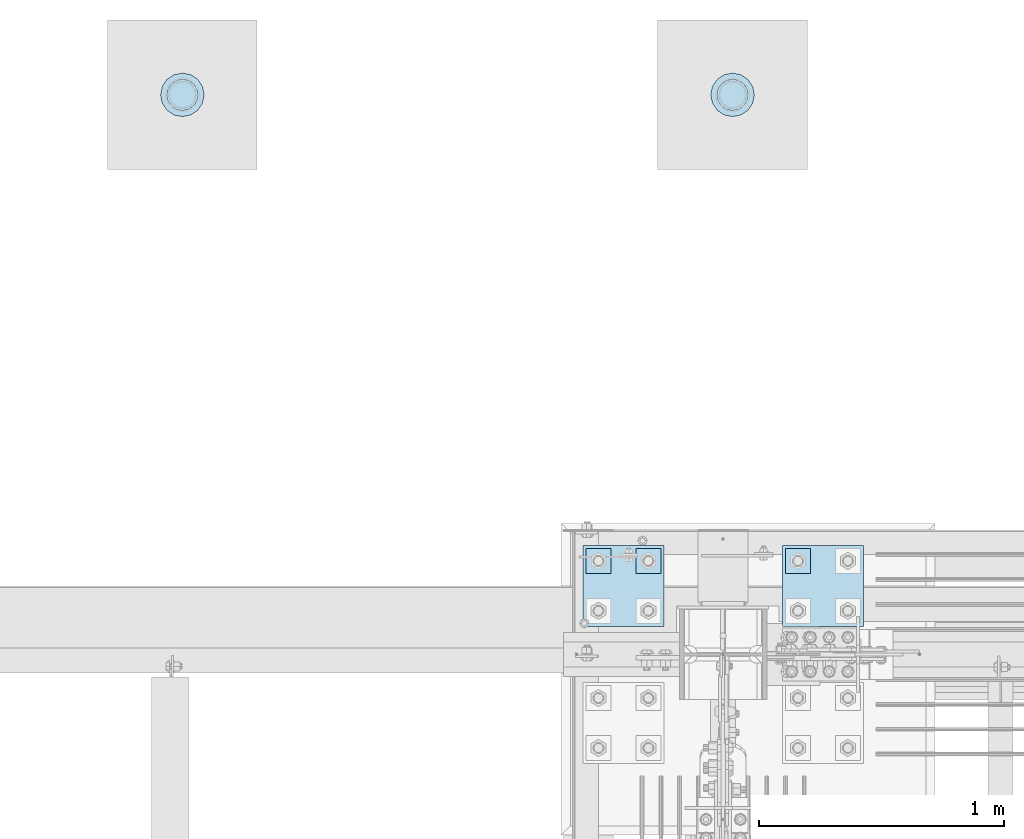
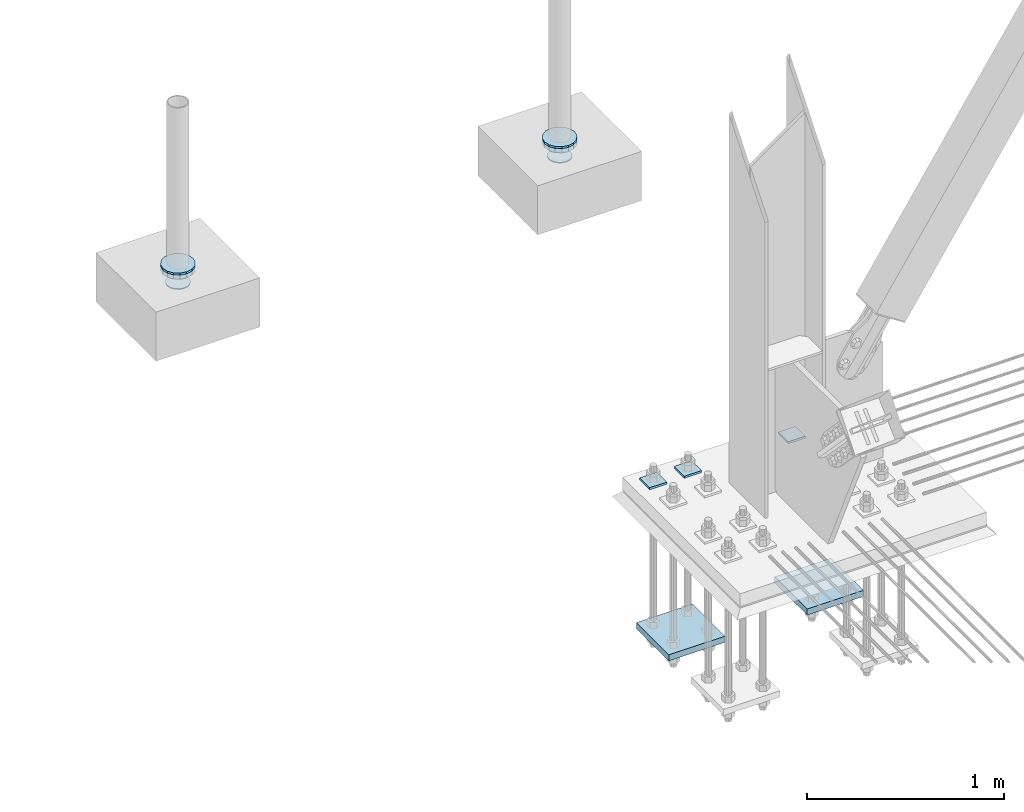
# One storey, part 3541 of 3843: 11 plates, 5 elements without a shape of their own.
"""IFC2X3 building model written with IfcOpenShell, lengths in millimetres."""

from ifc_helpers import new_model, si_unit, frame, origin_with_axes, place, context, subcontext, project, spatial, faceted_brep, material, type_object, element, aggregate, save


model = new_model("IFC2X3")

# Units and contexts
model_context = context("Model", 3, precision=1e-05, world=origin_with_axes())
body_context = subcontext(model_context, "Body", "Model", "MODEL_VIEW")
ifc_project = project(units=[si_unit("LENGTHUNIT", "METRE", prefix="MILLI"), si_unit("AREAUNIT", "SQUARE_METRE"), si_unit("VOLUMEUNIT", "CUBIC_METRE"), si_unit("MASSUNIT", "GRAM", prefix="KILO"), si_unit("TIMEUNIT", "SECOND"), si_unit("PLANEANGLEUNIT", "RADIAN"), si_unit("SOLIDANGLEUNIT", "STERADIAN"), si_unit("THERMODYNAMICTEMPERATUREUNIT", "DEGREE_CELSIUS"), si_unit("LUMINOUSINTENSITYUNIT", "LUMEN")], contexts=[model_context])

# Site, building, storey
site_placement = place(None, origin_with_axes())
site = spatial("IfcSite", under=ifc_project, at=site_placement, CompositionType="ELEMENT")
building_placement = place(site_placement, origin_with_axes())
building = spatial("IfcBuilding", under=site, at=building_placement, Name="Undefined", CompositionType="ELEMENT")
storey_placement = place(building_placement, origin_with_axes())
storey = spatial("IfcBuildingStorey", under=building, at=storey_placement, Name="Undefined", CompositionType="ELEMENT", Elevation=0.0)

# Assembly, plate
assembly_1_placement = place(storey_placement, origin_with_axes())
assembly_1 = element("IfcElementAssembly", 1, at=assembly_1_placement, inside=storey, Name="PIPE_BOLLARD", AssemblyPlace="NOTDEFINED", PredefinedType="RIGID_FRAME")
ifc_material = material(Name="STEEL/A572-50")
plate_type_1 = type_object("IfcPlateType", PredefinedType="NOTDEFINED")
plate_1_placement = place(assembly_1_placement, frame((76962.1673368275, 106927.878119135, 30486.35), z_axis=(1.0, 0.0, 0.0), x_axis=(0.0, -1.0, 0.0)))
plate_1 = element("IfcPlate", 2, at=plate_1_placement, type_object=plate_type_1, material=ifc_material, Name="PLATE", context=body_context, shape_type="Brep", body=[
    faceted_brep([(0.0, -6.34999999999854, 88.9000015258789), (6.76710967589679, -6.34999999999854, 122.920556195299), (6.76710967589679, 6.34999999999854, 122.920556195299), (0.0, 6.34999999999854, 88.9000015258789), (26.0382075994357, -6.34999999999854, 151.761792400561), (26.0382075994357, 6.34999999999854, 151.761792400561), (54.8794438046934, -6.34999999999854, 171.032890324102), (54.8794438046934, 6.34999999999854, 171.032890324102), (88.8999984741095, -6.34999999999854, 177.800000000003), (88.8999984741095, 6.34999999999854, 177.800000000003), (122.920556195295, -6.34999999999854, 171.032890324102), (122.920556195295, 6.34999999999854, 171.032890324102), (151.761792400553, -6.34999999999854, 151.761792400561), (151.761792400553, 6.34999999999854, 151.761792400561), (171.032890324092, -6.34999999999854, 122.920556195299), (171.032890324092, 6.34999999999854, 122.920556195299), (177.799999999988, -6.34999999999854, 88.9000015258789), (177.799999999988, 6.34999999999854, 88.9000015258789), (171.032890324091, -6.34999999999854, 54.8794438046898), (171.032890324091, 6.34999999999854, 54.8794438046898), (151.761792400553, -6.34999999999854, 26.0382075994421), (151.761792400553, 6.34999999999854, 26.0382075994421), (122.920556195295, -6.34999999999854, 6.76710967590043), (122.920556195295, 6.34999999999854, 6.76710967590043), (88.9000015258789, -6.34999999999854, 0.0), (88.9000015258789, 6.34999999999854, 0.0), (54.8794438046934, -6.34999999999854, 6.76710967590043), (54.8794438046934, 6.34999999999854, 6.76710967590043), (26.0382075994357, -6.34999999999854, 26.0382075994421), (26.0382075994357, 6.34999999999854, 26.0382075994421), (6.76710967589679, -6.34999999999854, 54.8794438046898), (6.76710967589679, 6.34999999999854, 54.8794438046898)], [[[0, 1, 2, 3]], [[1, 4, 5, 2]], [[4, 6, 7, 5]], [[6, 8, 9, 7]], [[8, 10, 11, 9]], [[10, 12, 13, 11]], [[12, 14, 15, 13]], [[14, 16, 17, 15]], [[16, 18, 19, 17]], [[18, 20, 21, 19]], [[20, 22, 23, 21]], [[22, 24, 25, 23]], [[24, 26, 27, 25]], [[26, 28, 29, 27]], [[28, 30, 31, 29]], [[30, 0, 3, 31]], [[5, 7, 9, 11, 13, 15, 17, 19, 21, 23, 25, 27, 29, 31, 3, 2]], [[30, 28, 26, 24, 22, 20, 18, 16, 14, 12, 10, 8, 6, 4, 1, 0]]]),
])
aggregate(assembly_1, [plate_1])

assembly_2_placement = place(storey_placement, origin_with_axes())
assembly_2 = element("IfcElementAssembly", 3, at=assembly_2_placement, inside=storey, Name="PIPE_BOLLARD", AssemblyPlace="NOTDEFINED", PredefinedType="RIGID_FRAME")
plate_2_placement = place(assembly_2_placement, frame((74720.7237027943, 106927.881933832, 30486.35), z_axis=(1.0, 0.0, 0.0), x_axis=(0.0, -1.0, 0.0)))
plate_2 = element("IfcPlate", 4, at=plate_2_placement, type_object=plate_type_1, material=ifc_material, Name="PLATE", context=body_context, shape_type="Brep", body=[
    faceted_brep([(0.0, -6.34999999999854, 88.9000015258789), (6.76710967589679, -6.34999999999854, 122.920556195299), (6.76710967589679, 6.34999999999854, 122.920556195299), (0.0, 6.34999999999854, 88.9000015258789), (26.0382075994357, -6.34999999999854, 151.761792400561), (26.0382075994357, 6.34999999999854, 151.761792400561), (54.8794438046934, -6.34999999999854, 171.032890324102), (54.8794438046934, 6.34999999999854, 171.032890324102), (88.8999984741095, -6.34999999999854, 177.800000000003), (88.8999984741095, 6.34999999999854, 177.800000000003), (122.920556195295, -6.34999999999854, 171.032890324102), (122.920556195295, 6.34999999999854, 171.032890324102), (151.761792400553, -6.34999999999854, 151.761792400561), (151.761792400553, 6.34999999999854, 151.761792400561), (171.032890324092, -6.34999999999854, 122.920556195299), (171.032890324092, 6.34999999999854, 122.920556195299), (177.799999999988, -6.34999999999854, 88.9000015258789), (177.799999999988, 6.34999999999854, 88.9000015258789), (171.032890324091, -6.34999999999854, 54.8794438046898), (171.032890324091, 6.34999999999854, 54.8794438046898), (151.761792400553, -6.34999999999854, 26.0382075994421), (151.761792400553, 6.34999999999854, 26.0382075994421), (122.920556195295, -6.34999999999854, 6.76710967590043), (122.920556195295, 6.34999999999854, 6.76710967590043), (88.9000015258789, -6.34999999999854, 0.0), (88.9000015258789, 6.34999999999854, 0.0), (54.8794438046934, -6.34999999999854, 6.76710967590043), (54.8794438046934, 6.34999999999854, 6.76710967590043), (26.0382075994357, -6.34999999999854, 26.0382075994421), (26.0382075994357, 6.34999999999854, 26.0382075994421), (6.76710967589679, -6.34999999999854, 54.8794438046898), (6.76710967589679, 6.34999999999854, 54.8794438046898)], [[[0, 1, 2, 3]], [[1, 4, 5, 2]], [[4, 6, 7, 5]], [[6, 8, 9, 7]], [[8, 10, 11, 9]], [[10, 12, 13, 11]], [[12, 14, 15, 13]], [[14, 16, 17, 15]], [[16, 18, 19, 17]], [[18, 20, 21, 19]], [[20, 22, 23, 21]], [[22, 24, 25, 23]], [[24, 26, 27, 25]], [[26, 28, 29, 27]], [[28, 30, 31, 29]], [[30, 0, 3, 31]], [[5, 7, 9, 11, 13, 15, 17, 19, 21, 23, 25, 27, 29, 31, 3, 2]], [[30, 28, 26, 24, 22, 20, 18, 16, 14, 12, 10, 8, 6, 4, 1, 0]]]),
])
aggregate(assembly_2, [plate_2])

assembly_3_placement = place(storey_placement, origin_with_axes())
assembly_3 = element("IfcElementAssembly", 5, at=assembly_3_placement, inside=storey, Name="PLATE", AssemblyPlace="NOTDEFINED", PredefinedType="RIGID_FRAME")
plate_type_2 = type_object("IfcPlateType", PredefinedType="NOTDEFINED")
plate_3_placement = place(assembly_3_placement, frame((76962.1673368275, 106927.878119135, 30467.3), z_axis=(1.0, 0.0, 0.0), x_axis=(0.0, -1.0, 0.0)))
plate_3 = element("IfcPlate", 6, at=plate_3_placement, type_object=plate_type_2, material=ifc_material, Name="PLATE", context=body_context, shape_type="Brep", body=[
    faceted_brep([(0.0, -12.7000000000007, 88.9000015258789), (6.76710967589679, -12.7000000000007, 122.920556195299), (6.76710967589679, 12.7000000000007, 122.920556195299), (0.0, 12.7000000000007, 88.9000015258789), (26.0382075994357, -12.7000000000007, 151.761792400561), (26.0382075994357, 12.7000000000007, 151.761792400561), (54.8794438046934, -12.7000000000007, 171.032890324102), (54.8794438046934, 12.7000000000007, 171.032890324102), (88.8999984741095, -12.7000000000007, 177.800000000003), (88.8999984741095, 12.7000000000007, 177.800000000003), (122.920556195295, -12.7000000000007, 171.032890324102), (122.920556195295, 12.7000000000007, 171.032890324102), (151.761792400553, -12.7000000000007, 151.761792400561), (151.761792400553, 12.7000000000007, 151.761792400561), (171.032890324092, -12.7000000000007, 122.920556195299), (171.032890324092, 12.7000000000007, 122.920556195299), (177.799999999988, -12.7000000000007, 88.9000015258789), (177.799999999988, 12.7000000000007, 88.9000015258789), (171.032890324091, -12.7000000000007, 54.8794438046898), (171.032890324091, 12.7000000000007, 54.8794438046898), (151.761792400553, -12.7000000000007, 26.0382075994421), (151.761792400553, 12.7000000000007, 26.0382075994421), (122.920556195295, -12.7000000000007, 6.76710967590043), (122.920556195295, 12.7000000000007, 6.76710967590043), (88.9000015258789, -12.7000000000007, 0.0), (88.9000015258789, 12.7000000000007, 0.0), (54.8794438046934, -12.7000000000007, 6.76710967590043), (54.8794438046934, 12.7000000000007, 6.76710967590043), (26.0382075994357, -12.7000000000007, 26.0382075994421), (26.0382075994357, 12.7000000000007, 26.0382075994421), (6.76710967589679, -12.7000000000007, 54.8794438046898), (6.76710967589679, 12.7000000000007, 54.8794438046898)], [[[0, 1, 2, 3]], [[1, 4, 5, 2]], [[4, 6, 7, 5]], [[6, 8, 9, 7]], [[8, 10, 11, 9]], [[10, 12, 13, 11]], [[12, 14, 15, 13]], [[14, 16, 17, 15]], [[16, 18, 19, 17]], [[18, 20, 21, 19]], [[20, 22, 23, 21]], [[22, 24, 25, 23]], [[24, 26, 27, 25]], [[26, 28, 29, 27]], [[28, 30, 31, 29]], [[30, 0, 3, 31]], [[5, 7, 9, 11, 13, 15, 17, 19, 21, 23, 25, 27, 29, 31, 3, 2]], [[30, 28, 26, 24, 22, 20, 18, 16, 14, 12, 10, 8, 6, 4, 1, 0]]]),
])

assembly_4_placement = place(storey_placement, origin_with_axes())
assembly_4 = element("IfcElementAssembly", 7, at=assembly_4_placement, inside=storey, Name="PLATE", AssemblyPlace="NOTDEFINED", PredefinedType="RIGID_FRAME")
plate_4_placement = place(assembly_4_placement, frame((74720.7237027943, 106927.881933832, 30467.3), z_axis=(1.0, 0.0, 0.0), x_axis=(0.0, -1.0, 0.0)))
plate_4 = element("IfcPlate", 8, at=plate_4_placement, type_object=plate_type_2, material=ifc_material, Name="PLATE", context=body_context, shape_type="Brep", body=[
    faceted_brep([(0.0, -12.7000000000007, 88.9000015258789), (6.76710967589679, -12.7000000000007, 122.920556195299), (6.76710967589679, 12.7000000000007, 122.920556195299), (0.0, 12.7000000000007, 88.9000015258789), (26.0382075994357, -12.7000000000007, 151.761792400561), (26.0382075994357, 12.7000000000007, 151.761792400561), (54.8794438046934, -12.7000000000007, 171.032890324102), (54.8794438046934, 12.7000000000007, 171.032890324102), (88.8999984741095, -12.7000000000007, 177.800000000003), (88.8999984741095, 12.7000000000007, 177.800000000003), (122.920556195295, -12.7000000000007, 171.032890324102), (122.920556195295, 12.7000000000007, 171.032890324102), (151.761792400553, -12.7000000000007, 151.761792400561), (151.761792400553, 12.7000000000007, 151.761792400561), (171.032890324092, -12.7000000000007, 122.920556195299), (171.032890324092, 12.7000000000007, 122.920556195299), (177.799999999988, -12.7000000000007, 88.9000015258789), (177.799999999988, 12.7000000000007, 88.9000015258789), (171.032890324091, -12.7000000000007, 54.8794438046898), (171.032890324091, 12.7000000000007, 54.8794438046898), (151.761792400553, -12.7000000000007, 26.0382075994421), (151.761792400553, 12.7000000000007, 26.0382075994421), (122.920556195295, -12.7000000000007, 6.76710967590043), (122.920556195295, 12.7000000000007, 6.76710967590043), (88.9000015258789, -12.7000000000007, 0.0), (88.9000015258789, 12.7000000000007, 0.0), (54.8794438046934, -12.7000000000007, 6.76710967590043), (54.8794438046934, 12.7000000000007, 6.76710967590043), (26.0382075994357, -12.7000000000007, 26.0382075994421), (26.0382075994357, 12.7000000000007, 26.0382075994421), (6.76710967589679, -12.7000000000007, 54.8794438046898), (6.76710967589679, 12.7000000000007, 54.8794438046898)], [[[0, 1, 2, 3]], [[1, 4, 5, 2]], [[4, 6, 7, 5]], [[6, 8, 9, 7]], [[8, 10, 11, 9]], [[10, 12, 13, 11]], [[12, 14, 15, 13]], [[14, 16, 17, 15]], [[16, 18, 19, 17]], [[18, 20, 21, 19]], [[20, 22, 23, 21]], [[22, 24, 25, 23]], [[24, 26, 27, 25]], [[26, 28, 29, 27]], [[28, 30, 31, 29]], [[30, 0, 3, 31]], [[5, 7, 9, 11, 13, 15, 17, 19, 21, 23, 25, 27, 29, 31, 3, 2]], [[30, 28, 26, 24, 22, 20, 18, 16, 14, 12, 10, 8, 6, 4, 1, 0]]]),
])

# Plate
plate_type_3 = type_object("IfcPlateType", PredefinedType="NOTDEFINED")
plate_5_placement = place(assembly_3_placement, frame((76987.0085368283, 106903.036919135, 30375.225), z_axis=(1.0, 0.0, 0.0), x_axis=(0.0, -1.0, 0.0)))
plate_5 = element("IfcPlate", 9, at=plate_5_placement, type_object=plate_type_3, material=ifc_material, Name="PLATE", context=body_context, shape_type="Brep", body=[
    faceted_brep([(0.0, -3.17499999999927, 63.5), (0.0, -3.17499999999927, 64.6175999984844), (0.0, 3.17499999999927, 64.6175999984844), (0.0, 3.17499999999927, 63.5), (4.8336496855336, -3.17499999999927, 88.9179979536566), (4.8336496855336, 3.17499999999927, 88.9179979536566), (18.5987193946494, -3.17499999999927, 109.51888060382), (18.5987193946494, 3.17499999999927, 109.51888060382), (39.1996020448132, -3.17499999999927, 123.283950312951), (39.1996020448132, 3.17499999999927, 123.283950312951), (63.5, -3.17499999999927, 128.117599998484), (63.5, 3.17499999999927, 128.117599998484), (64.6176000034029, -3.17499999999927, 128.117599998484), (64.6176000034029, 3.17499999999927, 128.117599998484), (88.9179979585897, -3.17499999999927, 123.283950312951), (88.9179979585897, 3.17499999999927, 123.283950312951), (109.518880608754, -3.17499999999927, 109.51888060382), (109.518880608754, 3.17499999999927, 109.51888060382), (123.283950317869, -3.17499999999927, 88.9179979536566), (123.283950317869, 3.17499999999927, 88.9179979536566), (128.117600003403, -3.17499999999927, 64.6175999984844), (128.117600003403, 3.17499999999927, 64.6175999984844), (128.117600003403, -3.17499999999927, 63.5), (128.117600003403, 3.17499999999927, 63.5), (123.283950317869, -3.17499999999927, 39.1996020448132), (123.283950317869, 3.17499999999927, 39.1996020448132), (109.518880608754, -3.17499999999927, 18.5987193946494), (109.518880608754, 3.17499999999927, 18.5987193946494), (88.9179979585897, -3.17499999999927, 4.8336496855336), (88.9179979585897, 3.17499999999927, 4.8336496855336), (64.6176000034029, -3.17499999999927, 0.0), (64.6176000034029, 3.17499999999927, 0.0), (63.5, -3.17499999999927, 0.0), (63.5, 3.17499999999927, 0.0), (39.1996020448132, -3.17499999999927, 4.8336496855336), (39.1996020448132, 3.17499999999927, 4.8336496855336), (18.5987193946494, -3.17499999999927, 18.5987193946494), (18.5987193946494, 3.17499999999927, 18.5987193946494), (4.8336496855336, -3.17499999999927, 39.1996020448132), (4.8336496855336, 3.17499999999927, 39.1996020448132)], [[[0, 1, 2, 3]], [[1, 4, 5, 2]], [[4, 6, 7, 5]], [[6, 8, 9, 7]], [[8, 10, 11, 9]], [[10, 12, 13, 11]], [[12, 14, 15, 13]], [[14, 16, 17, 15]], [[16, 18, 19, 17]], [[18, 20, 21, 19]], [[20, 22, 23, 21]], [[22, 24, 25, 23]], [[24, 26, 27, 25]], [[26, 28, 29, 27]], [[28, 30, 31, 29]], [[30, 32, 33, 31]], [[32, 34, 35, 33]], [[34, 36, 37, 35]], [[36, 38, 39, 37]], [[38, 0, 3, 39]], [[5, 7, 9, 11, 13, 15, 17, 19, 21, 23, 25, 27, 29, 31, 33, 35, 37, 39, 3, 2]], [[38, 36, 34, 32, 30, 28, 26, 24, 22, 20, 18, 16, 14, 12, 10, 8, 6, 4, 1, 0]]]),
])

aggregate(assembly_3, [plate_5, plate_3])

plate_6_placement = place(assembly_4_placement, frame((74745.5649027951, 106903.040733832, 30375.225), z_axis=(1.0, 0.0, 0.0), x_axis=(0.0, -1.0, 0.0)))
plate_6 = element("IfcPlate", 10, at=plate_6_placement, type_object=plate_type_3, material=ifc_material, Name="PLATE", context=body_context, shape_type="Brep", body=[
    faceted_brep([(0.0, -3.17499999999927, 63.5), (0.0, -3.17499999999927, 64.6175999984844), (0.0, 3.17499999999927, 64.6175999984844), (0.0, 3.17499999999927, 63.5), (4.8336496855336, -3.17499999999927, 88.9179979536566), (4.8336496855336, 3.17499999999927, 88.9179979536566), (18.5987193946494, -3.17499999999927, 109.51888060382), (18.5987193946494, 3.17499999999927, 109.51888060382), (39.1996020448132, -3.17499999999927, 123.283950312951), (39.1996020448132, 3.17499999999927, 123.283950312951), (63.5, -3.17499999999927, 128.117599998484), (63.5, 3.17499999999927, 128.117599998484), (64.6176000034029, -3.17499999999927, 128.117599998484), (64.6176000034029, 3.17499999999927, 128.117599998484), (88.9179979585897, -3.17499999999927, 123.283950312951), (88.9179979585897, 3.17499999999927, 123.283950312951), (109.518880608754, -3.17499999999927, 109.51888060382), (109.518880608754, 3.17499999999927, 109.51888060382), (123.283950317869, -3.17499999999927, 88.9179979536566), (123.283950317869, 3.17499999999927, 88.9179979536566), (128.117600003403, -3.17499999999927, 64.6175999984844), (128.117600003403, 3.17499999999927, 64.6175999984844), (128.117600003403, -3.17499999999927, 63.5), (128.117600003403, 3.17499999999927, 63.5), (123.283950317869, -3.17499999999927, 39.1996020448132), (123.283950317869, 3.17499999999927, 39.1996020448132), (109.518880608754, -3.17499999999927, 18.5987193946494), (109.518880608754, 3.17499999999927, 18.5987193946494), (88.9179979585897, -3.17499999999927, 4.8336496855336), (88.9179979585897, 3.17499999999927, 4.8336496855336), (64.6176000034029, -3.17499999999927, 0.0), (64.6176000034029, 3.17499999999927, 0.0), (63.5, -3.17499999999927, 0.0), (63.5, 3.17499999999927, 0.0), (39.1996020448132, -3.17499999999927, 4.8336496855336), (39.1996020448132, 3.17499999999927, 4.8336496855336), (18.5987193946494, -3.17499999999927, 18.5987193946494), (18.5987193946494, 3.17499999999927, 18.5987193946494), (4.8336496855336, -3.17499999999927, 39.1996020448132), (4.8336496855336, 3.17499999999927, 39.1996020448132)], [[[0, 1, 2, 3]], [[1, 4, 5, 2]], [[4, 6, 7, 5]], [[6, 8, 9, 7]], [[8, 10, 11, 9]], [[10, 12, 13, 11]], [[12, 14, 15, 13]], [[14, 16, 17, 15]], [[16, 18, 19, 17]], [[18, 20, 21, 19]], [[20, 22, 23, 21]], [[22, 24, 25, 23]], [[24, 26, 27, 25]], [[26, 28, 29, 27]], [[28, 30, 31, 29]], [[30, 32, 33, 31]], [[32, 34, 35, 33]], [[34, 36, 37, 35]], [[36, 38, 39, 37]], [[38, 0, 3, 39]], [[5, 7, 9, 11, 13, 15, 17, 19, 21, 23, 25, 27, 29, 31, 33, 35, 37, 39, 3, 2]], [[38, 36, 34, 32, 30, 28, 26, 24, 22, 20, 18, 16, 14, 12, 10, 8, 6, 4, 1, 0]]]),
])

aggregate(assembly_4, [plate_6, plate_4])

# Assembly, plates
assembly_5_placement = place(storey_placement, origin_with_axes())
assembly_5 = element("IfcElementAssembly", 11, at=assembly_5_placement, inside=storey, Name="TEMPLATE", AssemblyPlace="NOTDEFINED", PredefinedType="RIGID_FRAME")
plate_type_4 = type_object("IfcPlateType", PredefinedType="NOTDEFINED")
plate_7_placement = place(assembly_5_placement, frame((77266.8, 104990.9, 29698.95), z_axis=(0.0, -1.0, 0.0), x_axis=(1.0, 0.0, 0.0)))
plate_7 = element("IfcPlate", 12, at=plate_7_placement, type_object=plate_type_4, material=ifc_material, Name="Washer Plate", context=body_context, shape_type="Brep", body=[
    faceted_brep([(0.0, -6.3499999046162, 0.0), (-1.67347025126219e-10, -6.35000000000582, 101.600000000151), (-1.67347025126219e-10, 6.35000000000582, 101.600000000151), (7.27595761418343e-12, 6.3499999046162, 0.0), (101.599998474121, -6.34999999999854, 101.599998474121), (101.599998474121, 6.34999999999854, 101.599998474121), (101.6, -6.34999999999854, 0.0), (101.6, 6.34999999999854, 0.0)], [[[0, 1, 2, 3]], [[1, 4, 5, 2]], [[4, 6, 7, 5]], [[6, 0, 3, 7]], [[5, 7, 3, 2]], [[6, 4, 1, 0]]]),
])
plate_8_placement = place(assembly_5_placement, frame((76657.2, 104990.9, 29698.95), z_axis=(0.0, -1.0, 0.0), x_axis=(1.0, 0.0, 0.0)))
plate_8 = element("IfcPlate", 13, at=plate_8_placement, type_object=plate_type_4, material=ifc_material, Name="Washer Plate", context=body_context, shape_type="Brep", body=[
    faceted_brep([(0.0, -6.3499999046162, 0.0), (-1.67347025126219e-10, -6.35000000000582, 101.600000000151), (-1.67347025126219e-10, 6.35000000000582, 101.600000000151), (7.27595761418343e-12, 6.3499999046162, 0.0), (101.599998474121, -6.34999999999854, 101.599998474121), (101.599998474121, 6.34999999999854, 101.599998474121), (101.6, -6.34999999999854, 0.0), (101.6, 6.34999999999854, 0.0)], [[[0, 1, 2, 3]], [[1, 4, 5, 2]], [[4, 6, 7, 5]], [[6, 0, 3, 7]], [[5, 7, 3, 2]], [[6, 4, 1, 0]]]),
])
plate_9_placement = place(assembly_5_placement, frame((76454.0, 104990.9, 29698.95), z_axis=(0.0, -1.0, 0.0), x_axis=(1.0, 0.0, 0.0)))
plate_9 = element("IfcPlate", 14, at=plate_9_placement, type_object=plate_type_4, material=ifc_material, Name="Washer Plate", context=body_context, shape_type="Brep", body=[
    faceted_brep([(0.0, -6.3499999046162, 0.0), (-1.67347025126219e-10, -6.35000000000582, 101.600000000151), (-1.67347025126219e-10, 6.35000000000582, 101.600000000151), (7.27595761418343e-12, 6.3499999046162, 0.0), (101.599998474121, -6.34999999999854, 101.599998474121), (101.599998474121, 6.34999999999854, 101.599998474121), (101.6, -6.34999999999854, 0.0), (101.6, 6.34999999999854, 0.0)], [[[0, 1, 2, 3]], [[1, 4, 5, 2]], [[4, 6, 7, 5]], [[6, 0, 3, 7]], [[5, 7, 3, 2]], [[6, 4, 1, 0]]]),
])
plate_type_5 = type_object("IfcPlateType", PredefinedType="NOTDEFINED")
plate_10_placement = place(assembly_5_placement, frame((76441.3, 105003.600003052, 28784.55), z_axis=(1.0, 0.0, 0.0), x_axis=(0.0, -1.0, 0.0)))
plate_10 = element("IfcPlate", 15, at=plate_10_placement, type_object=plate_type_5, material=ifc_material, Name="PLATE", context=body_context, shape_type="Brep", body=[
    faceted_brep([(0.0, -19.0500000000029, 0.0), (0.0, -19.0499999999993, 330.200012207031), (0.0, 19.0499999999993, 330.200012207031), (0.0, 19.0500000000029, 0.0), (330.200012207031, -19.0499999999993, 330.200012207031), (330.200012207031, 19.0499999999993, 330.200012207031), (330.200012207031, -19.0499999999993, 0.0), (330.200012207031, 19.0499999999993, 0.0)], [[[0, 1, 2, 3]], [[1, 4, 5, 2]], [[4, 6, 7, 5]], [[6, 0, 3, 7]], [[5, 7, 3, 2]], [[6, 4, 1, 0]]]),
])
plate_11_placement = place(assembly_5_placement, frame((77254.1, 105003.600003052, 28784.55), z_axis=(1.0, 0.0, 0.0), x_axis=(0.0, -1.0, 0.0)))
plate_11 = element("IfcPlate", 16, at=plate_11_placement, type_object=plate_type_5, material=ifc_material, Name="PLATE", context=body_context, shape_type="Brep", body=[
    faceted_brep([(0.0, -19.0500000000029, 0.0), (0.0, -19.0499999999993, 330.200012207031), (0.0, 19.0499999999993, 330.200012207031), (0.0, 19.0500000000029, 0.0), (330.200012207031, -19.0499999999993, 330.200012207031), (330.200012207031, 19.0499999999993, 330.200012207031), (330.200012207031, -19.0499999999993, 0.0), (330.200012207031, 19.0499999999993, 0.0)], [[[0, 1, 2, 3]], [[1, 4, 5, 2]], [[4, 6, 7, 5]], [[6, 0, 3, 7]], [[5, 7, 3, 2]], [[6, 4, 1, 0]]]),
])
aggregate(assembly_5, [plate_10, plate_11, plate_7, plate_8, plate_9])

save(model, "model.ifc")
